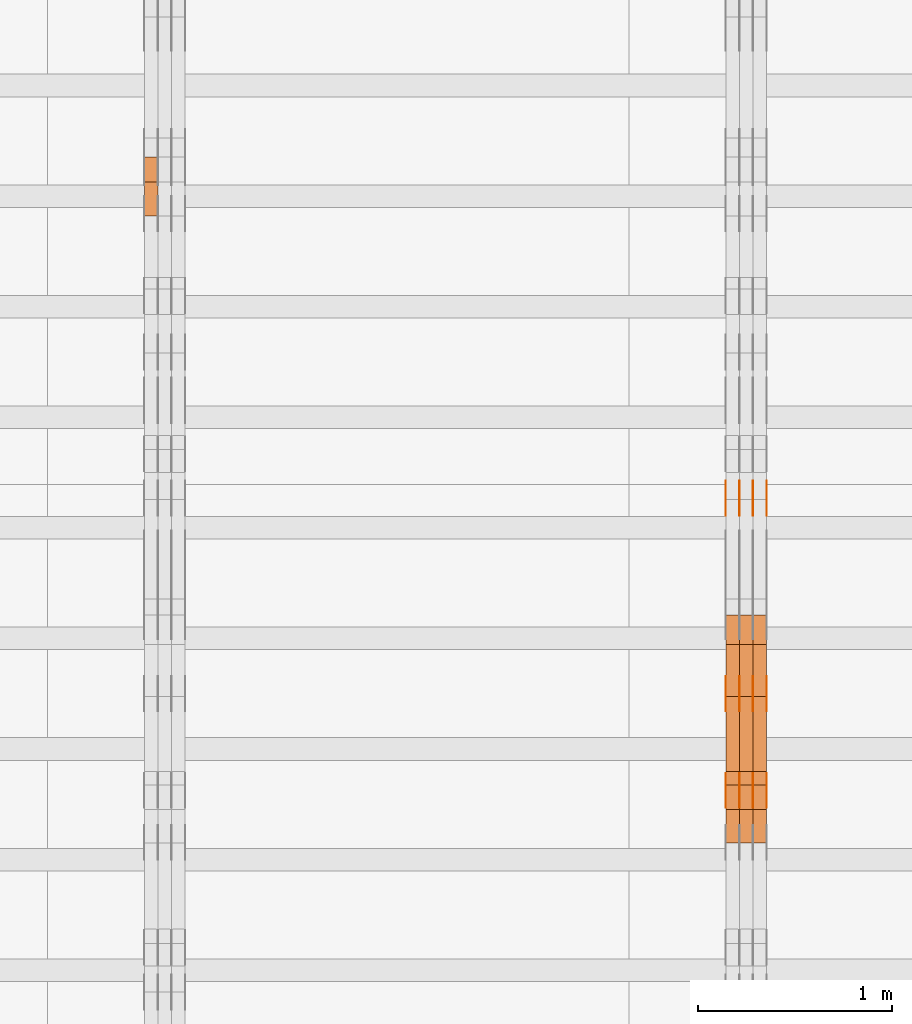
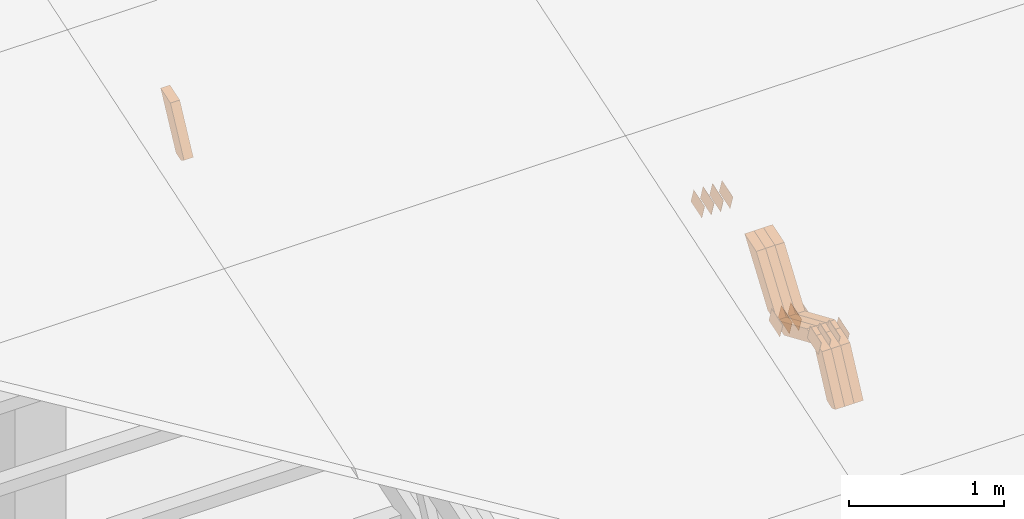
# One storey, part 118 of 385: 28 proxies.
"""IFC2X3 building model written with IfcOpenShell, lengths in millimetres."""

from ifc_helpers import new_model, entity, si_unit, converted_unit, derived_unit, direction, frame, origin, place, context, subcontext, project, spatial, polyline, outline, extrude, source, transform, mapped, material, type_object, type_shapes, element, save


model = new_model("IFC2X3")

# Units and contexts
model_context = context("Model", 3, precision=0.01, world=origin(), true_north=direction((6.12303176911189e-17, 1.0)))
body_context = subcontext(model_context, "Body", "Model", "MODEL_VIEW")
ifc_project = project(units=[si_unit("LENGTHUNIT", "METRE", prefix="MILLI"), si_unit("AREAUNIT", "SQUARE_METRE"), si_unit("VOLUMEUNIT", "CUBIC_METRE"), converted_unit("PLANEANGLEUNIT", "DEGREE", entity("IfcRatioMeasure", 0.0174532925199433), si_unit("PLANEANGLEUNIT", "RADIAN"), dimensions=[0, 0, 0, 0, 0, 0, 0]), si_unit("MASSUNIT", "GRAM", prefix="KILO"), derived_unit("MASSDENSITYUNIT", [(si_unit("MASSUNIT", "GRAM", prefix="KILO"), 1), (si_unit("LENGTHUNIT", "METRE"), -3)]), si_unit("TIMEUNIT", "SECOND"), si_unit("FREQUENCYUNIT", "HERTZ"), si_unit("THERMODYNAMICTEMPERATUREUNIT", "DEGREE_CELSIUS"), derived_unit("THERMALTRANSMITTANCEUNIT", [(si_unit("MASSUNIT", "GRAM", prefix="KILO"), 1), (si_unit("THERMODYNAMICTEMPERATUREUNIT", "KELVIN"), -1), (si_unit("TIMEUNIT", "SECOND"), -3)]), derived_unit("VOLUMETRICFLOWRATEUNIT", [(si_unit("LENGTHUNIT", "METRE"), 3), (si_unit("TIMEUNIT", "SECOND"), -1)]), si_unit("ELECTRICCURRENTUNIT", "AMPERE"), si_unit("ELECTRICVOLTAGEUNIT", "VOLT"), si_unit("POWERUNIT", "WATT"), si_unit("FORCEUNIT", "NEWTON", prefix="KILO"), si_unit("ILLUMINANCEUNIT", "LUX"), si_unit("LUMINOUSFLUXUNIT", "LUMEN"), si_unit("LUMINOUSINTENSITYUNIT", "CANDELA"), derived_unit("USERDEFINED", [(si_unit("MASSUNIT", "GRAM", prefix="KILO"), -1), (si_unit("LENGTHUNIT", "METRE"), -2), (si_unit("TIMEUNIT", "SECOND"), 3), (si_unit("LUMINOUSFLUXUNIT", "LUMEN"), 1)]), derived_unit("LINEARVELOCITYUNIT", [(si_unit("LENGTHUNIT", "METRE"), 1), (si_unit("TIMEUNIT", "SECOND"), -1)]), si_unit("PRESSUREUNIT", "PASCAL"), derived_unit("USERDEFINED", [(si_unit("LENGTHUNIT", "METRE"), -2), (si_unit("MASSUNIT", "GRAM", prefix="KILO"), 1), (si_unit("TIMEUNIT", "SECOND"), -2)])], contexts=[model_context])

# Site, building, storey
site_placement = place(None, origin())
site = spatial("IfcSite", under=ifc_project, at=site_placement, CompositionType="ELEMENT")
building_placement = place(site_placement, origin())
building = spatial("IfcBuilding", under=site, at=building_placement, CompositionType="ELEMENT")
storey_placement = place(building_placement, origin())
storey = spatial("IfcBuildingStorey", under=building, at=storey_placement, Name="Default", CompositionType="ELEMENT", Elevation=0.0)

# Proxies
ifc_material_1 = material(Name="IfcSurfaceStyle #281766")
building_element_proxy_type_1 = type_object("IfcBuildingElementProxyType", PredefinedType="NOTDEFINED", material=ifc_material_1)
shared_shape_1 = source(origin(), body_context, "Body", "SweptSolid", [
    extrude(outline(polyline([(-74.9998565677179, -60.000059685226), (74.9998794200128, -60.000059685226), (74.9998565677179, 60.000059685226), (-74.9998794200128, 60.000059685226), (-74.9998565677179, -60.000059685226)])), frame((75.0001976720505, 60.000059685226, 0.0), z_axis=(0.0, 0.0, 1.0), x_axis=(-1.0, 0.0, 0.0)), (0.0, 0.0, 1.0), 1.3),
])
type_shapes(building_element_proxy_type_1, [shared_shape_1])
proxy_1_placement = place(building_placement, frame((21386.3, 8537.53090236182, 1950.11166041942), z_axis=(-1.0, 0.0, 0.0), x_axis=(0.0, 0.951056516295124, 0.309016994375039)))
element("IfcBuildingElementProxy", 1, at=proxy_1_placement, inside=storey, type_object=building_element_proxy_type_1, material=ifc_material_1, context=body_context, shape_type="MappedRepresentation", body=[
    mapped(shared_shape_1, transform((0.0, 0.0, 0.0), scale=1.0)),
])
ifc_material_2 = material(Name="IfcSurfaceStyle #281709")
building_element_proxy_type_2 = type_object("IfcBuildingElementProxyType", PredefinedType="NOTDEFINED", material=ifc_material_2)
shared_shape_2 = source(origin(), body_context, "Body", "SweptSolid", [
    extrude(outline(polyline([(-74.9998565677179, -60.000059685226), (74.9998794200128, -60.000059685226), (74.9998565677179, 60.000059685226), (-74.9998794200128, 60.000059685226), (-74.9998565677179, -60.000059685226)])), frame((75.0001976720505, 60.000059685226, 0.0), z_axis=(0.0, 0.0, 1.0), x_axis=(-1.0, 0.0, 0.0)), (0.0, 0.0, 1.0), 1.3),
])
type_shapes(building_element_proxy_type_2, [shared_shape_2])
proxy_2_placement = place(building_placement, frame((21315.0, 8537.53090236182, 1950.11166041942), z_axis=(-1.0, 0.0, 0.0), x_axis=(0.0, 0.951056516295124, 0.309016994375039)))
element("IfcBuildingElementProxy", 2, at=proxy_2_placement, inside=storey, type_object=building_element_proxy_type_2, material=ifc_material_2, context=body_context, shape_type="MappedRepresentation", body=[
    mapped(shared_shape_2, transform((0.0, 0.0, 0.0), scale=1.0)),
])
ifc_material_3 = material(Name="IfcSurfaceStyle #281652")
building_element_proxy_type_3 = type_object("IfcBuildingElementProxyType", PredefinedType="NOTDEFINED", material=ifc_material_3)
shared_shape_3 = source(origin(), body_context, "Body", "SweptSolid", [
    extrude(outline(polyline([(-74.9998565677179, -60.000059685226), (74.9998794200128, -60.000059685226), (74.9998565677179, 60.000059685226), (-74.9998794200128, 60.000059685226), (-74.9998565677179, -60.000059685226)])), frame((75.0001976720505, 60.000059685226, 0.0), z_axis=(0.0, 0.0, 1.0), x_axis=(-1.0, 0.0, 0.0)), (0.0, 0.0, 1.0), 1.3),
])
type_shapes(building_element_proxy_type_3, [shared_shape_3])
proxy_3_placement = place(building_placement, frame((21316.3, 8537.53090236182, 1950.11166041942), z_axis=(-1.0, 0.0, 0.0), x_axis=(0.0, 0.951056516295124, 0.309016994375039)))
element("IfcBuildingElementProxy", 3, at=proxy_3_placement, inside=storey, type_object=building_element_proxy_type_3, material=ifc_material_3, context=body_context, shape_type="MappedRepresentation", body=[
    mapped(shared_shape_3, transform((0.0, 0.0, 0.0), scale=1.0)),
])
ifc_material_4 = material(Name="IfcSurfaceStyle #281595")
building_element_proxy_type_4 = type_object("IfcBuildingElementProxyType", PredefinedType="NOTDEFINED", material=ifc_material_4)
shared_shape_4 = source(origin(), body_context, "Body", "SweptSolid", [
    extrude(outline(polyline([(-74.9998565677179, -60.000059685226), (74.9998794200128, -60.000059685226), (74.9998565677179, 60.000059685226), (-74.9998794200128, 60.000059685226), (-74.9998565677179, -60.000059685226)])), frame((75.0001976720505, 60.000059685226, 0.0), z_axis=(0.0, 0.0, 1.0), x_axis=(-1.0, 0.0, 0.0)), (0.0, 0.0, 1.0), 1.29999999999999),
])
type_shapes(building_element_proxy_type_4, [shared_shape_4])
proxy_4_placement = place(building_placement, frame((21245.0, 8537.53090236182, 1950.11166041942), z_axis=(-1.0, 0.0, 0.0), x_axis=(0.0, 0.951056516295124, 0.309016994375039)))
element("IfcBuildingElementProxy", 4, at=proxy_4_placement, inside=storey, type_object=building_element_proxy_type_4, material=ifc_material_4, context=body_context, shape_type="MappedRepresentation", body=[
    mapped(shared_shape_4, transform((0.0, 0.0, 0.0), scale=1.0)),
])
ifc_material_5 = material(Name="IfcSurfaceStyle #281538")
building_element_proxy_type_5 = type_object("IfcBuildingElementProxyType", PredefinedType="NOTDEFINED", material=ifc_material_5)
shared_shape_5 = source(origin(), body_context, "Body", "SweptSolid", [
    extrude(outline(polyline([(-74.9998565677179, -60.000059685226), (74.9998794200128, -60.000059685226), (74.9998565677179, 60.000059685226), (-74.9998794200128, 60.000059685226), (-74.9998565677179, -60.000059685226)])), frame((75.0001976720505, 60.000059685226, 0.0), z_axis=(0.0, 0.0, 1.0), x_axis=(-1.0, 0.0, 0.0)), (0.0, 0.0, 1.0), 1.29999999999999),
])
type_shapes(building_element_proxy_type_5, [shared_shape_5])
proxy_5_placement = place(building_placement, frame((21246.3, 8537.53090236182, 1950.11166041942), z_axis=(-1.0, 0.0, 0.0), x_axis=(0.0, 0.951056516295124, 0.309016994375039)))
element("IfcBuildingElementProxy", 5, at=proxy_5_placement, inside=storey, type_object=building_element_proxy_type_5, material=ifc_material_5, context=body_context, shape_type="MappedRepresentation", body=[
    mapped(shared_shape_5, transform((0.0, 0.0, 0.0), scale=1.0)),
])
ifc_material_6 = material(Name="IfcSurfaceStyle #281481")
building_element_proxy_type_6 = type_object("IfcBuildingElementProxyType", PredefinedType="NOTDEFINED", material=ifc_material_6)
shared_shape_6 = source(origin(), body_context, "Body", "SweptSolid", [
    extrude(outline(polyline([(-74.9998565677179, -60.000059685226), (74.9998794200128, -60.000059685226), (74.9998565677179, 60.000059685226), (-74.9998794200128, 60.000059685226), (-74.9998565677179, -60.000059685226)])), frame((75.0001976720505, 60.000059685226, 0.0), z_axis=(0.0, 0.0, 1.0), x_axis=(-1.0, 0.0, 0.0)), (0.0, 0.0, 1.0), 1.29999999999999),
])
type_shapes(building_element_proxy_type_6, [shared_shape_6])
proxy_6_placement = place(building_placement, frame((21175.0, 8537.53090236182, 1950.11166041942), z_axis=(-1.0, 0.0, 0.0), x_axis=(0.0, 0.951056516295124, 0.309016994375039)))
element("IfcBuildingElementProxy", 6, at=proxy_6_placement, inside=storey, type_object=building_element_proxy_type_6, material=ifc_material_6, context=body_context, shape_type="MappedRepresentation", body=[
    mapped(shared_shape_6, transform((0.0, 0.0, 0.0), scale=1.0)),
])
ifc_material_7 = material(Name="IfcSurfaceStyle #276636")
building_element_proxy_type_7 = type_object("IfcBuildingElementProxyType", PredefinedType="NOTDEFINED", material=ifc_material_7)
shared_shape_7 = source(origin(), body_context, "Body", "SweptSolid", [
    extrude(outline(polyline([(-74.9998565677169, -60.0000596852269), (74.9998794200137, -60.0000596852269), (74.9998565677151, 60.0000596852269), (-74.9998794200119, 60.0000596852269), (-74.9998565677169, -60.0000596852269)])), frame((74.9998794200137, 60.0000596852269, 0.0), z_axis=(0.0, 0.0, 1.0), x_axis=(-1.0, 0.0, 0.0)), (0.0, 0.0, 1.0), 1.3),
])
type_shapes(building_element_proxy_type_7, [shared_shape_7])
proxy_7_placement = place(building_placement, frame((21386.3, 7527.6269081625, 1621.97418552253), z_axis=(-1.0, 0.0, 0.0), x_axis=(0.0, 0.951056516295124, 0.309016994375039)))
element("IfcBuildingElementProxy", 7, at=proxy_7_placement, inside=storey, type_object=building_element_proxy_type_7, material=ifc_material_7, context=body_context, shape_type="MappedRepresentation", body=[
    mapped(shared_shape_7, transform((0.0, 0.0, 0.0), scale=1.0)),
])
ifc_material_8 = material(Name="IfcSurfaceStyle #276579")
building_element_proxy_type_8 = type_object("IfcBuildingElementProxyType", PredefinedType="NOTDEFINED", material=ifc_material_8)
shared_shape_8 = source(origin(), body_context, "Body", "SweptSolid", [
    extrude(outline(polyline([(-74.9998565677169, -60.0000596852269), (74.9998794200137, -60.0000596852269), (74.9998565677151, 60.0000596852269), (-74.9998794200119, 60.0000596852269), (-74.9998565677169, -60.0000596852269)])), frame((74.9998794200137, 60.0000596852269, 0.0), z_axis=(0.0, 0.0, 1.0), x_axis=(-1.0, 0.0, 0.0)), (0.0, 0.0, 1.0), 1.3),
])
type_shapes(building_element_proxy_type_8, [shared_shape_8])
proxy_8_placement = place(building_placement, frame((21315.0, 7527.6269081625, 1621.97418552253), z_axis=(-1.0, 0.0, 0.0), x_axis=(0.0, 0.951056516295124, 0.309016994375039)))
element("IfcBuildingElementProxy", 8, at=proxy_8_placement, inside=storey, type_object=building_element_proxy_type_8, material=ifc_material_8, context=body_context, shape_type="MappedRepresentation", body=[
    mapped(shared_shape_8, transform((0.0, 0.0, 0.0), scale=1.0)),
])
ifc_material_9 = material(Name="IfcSurfaceStyle #276522")
building_element_proxy_type_9 = type_object("IfcBuildingElementProxyType", PredefinedType="NOTDEFINED", material=ifc_material_9)
shared_shape_9 = source(origin(), body_context, "Body", "SweptSolid", [
    extrude(outline(polyline([(-74.9998565677169, -60.0000596852269), (74.9998794200137, -60.0000596852269), (74.9998565677151, 60.0000596852269), (-74.9998794200119, 60.0000596852269), (-74.9998565677169, -60.0000596852269)])), frame((74.9998794200137, 60.0000596852269, 0.0), z_axis=(0.0, 0.0, 1.0), x_axis=(-1.0, 0.0, 0.0)), (0.0, 0.0, 1.0), 1.3),
])
type_shapes(building_element_proxy_type_9, [shared_shape_9])
proxy_9_placement = place(building_placement, frame((21316.3, 7527.6269081625, 1621.97418552253), z_axis=(-1.0, 0.0, 0.0), x_axis=(0.0, 0.951056516295124, 0.309016994375039)))
element("IfcBuildingElementProxy", 9, at=proxy_9_placement, inside=storey, type_object=building_element_proxy_type_9, material=ifc_material_9, context=body_context, shape_type="MappedRepresentation", body=[
    mapped(shared_shape_9, transform((0.0, 0.0, 0.0), scale=1.0)),
])
ifc_material_10 = material(Name="IfcSurfaceStyle #276465")
building_element_proxy_type_10 = type_object("IfcBuildingElementProxyType", PredefinedType="NOTDEFINED", material=ifc_material_10)
shared_shape_10 = source(origin(), body_context, "Body", "SweptSolid", [
    extrude(outline(polyline([(-74.9998565677169, -60.0000596852269), (74.9998794200137, -60.0000596852269), (74.9998565677151, 60.0000596852269), (-74.9998794200119, 60.0000596852269), (-74.9998565677169, -60.0000596852269)])), frame((74.9998794200137, 60.0000596852269, 0.0), z_axis=(0.0, 0.0, 1.0), x_axis=(-1.0, 0.0, 0.0)), (0.0, 0.0, 1.0), 1.29999999999999),
])
type_shapes(building_element_proxy_type_10, [shared_shape_10])
proxy_10_placement = place(building_placement, frame((21245.0, 7527.6269081625, 1621.97418552253), z_axis=(-1.0, 0.0, 0.0), x_axis=(0.0, 0.951056516295124, 0.309016994375039)))
element("IfcBuildingElementProxy", 10, at=proxy_10_placement, inside=storey, type_object=building_element_proxy_type_10, material=ifc_material_10, context=body_context, shape_type="MappedRepresentation", body=[
    mapped(shared_shape_10, transform((0.0, 0.0, 0.0), scale=1.0)),
])
ifc_material_11 = material(Name="IfcSurfaceStyle #276408")
building_element_proxy_type_11 = type_object("IfcBuildingElementProxyType", PredefinedType="NOTDEFINED", material=ifc_material_11)
shared_shape_11 = source(origin(), body_context, "Body", "SweptSolid", [
    extrude(outline(polyline([(-74.9998565677169, -60.0000596852269), (74.9998794200137, -60.0000596852269), (74.9998565677151, 60.0000596852269), (-74.9998794200119, 60.0000596852269), (-74.9998565677169, -60.0000596852269)])), frame((74.9998794200137, 60.0000596852269, 0.0), z_axis=(0.0, 0.0, 1.0), x_axis=(-1.0, 0.0, 0.0)), (0.0, 0.0, 1.0), 1.29999999999999),
])
type_shapes(building_element_proxy_type_11, [shared_shape_11])
proxy_11_placement = place(building_placement, frame((21246.3, 7527.6269081625, 1621.97418552253), z_axis=(-1.0, 0.0, 0.0), x_axis=(0.0, 0.951056516295124, 0.309016994375039)))
element("IfcBuildingElementProxy", 11, at=proxy_11_placement, inside=storey, type_object=building_element_proxy_type_11, material=ifc_material_11, context=body_context, shape_type="MappedRepresentation", body=[
    mapped(shared_shape_11, transform((0.0, 0.0, 0.0), scale=1.0)),
])
ifc_material_12 = material(Name="IfcSurfaceStyle #276351")
building_element_proxy_type_12 = type_object("IfcBuildingElementProxyType", PredefinedType="NOTDEFINED", material=ifc_material_12)
shared_shape_12 = source(origin(), body_context, "Body", "SweptSolid", [
    extrude(outline(polyline([(-74.9998565677169, -60.0000596852269), (74.9998794200137, -60.0000596852269), (74.9998565677151, 60.0000596852269), (-74.9998794200119, 60.0000596852269), (-74.9998565677169, -60.0000596852269)])), frame((74.9998794200137, 60.0000596852269, 0.0), z_axis=(0.0, 0.0, 1.0), x_axis=(-1.0, 0.0, 0.0)), (0.0, 0.0, 1.0), 1.29999999999999),
])
type_shapes(building_element_proxy_type_12, [shared_shape_12])
proxy_12_placement = place(building_placement, frame((21175.0, 7527.6269081625, 1621.97418552253), z_axis=(-1.0, 0.0, 0.0), x_axis=(0.0, 0.951056516295124, 0.309016994375039)))
element("IfcBuildingElementProxy", 12, at=proxy_12_placement, inside=storey, type_object=building_element_proxy_type_12, material=ifc_material_12, context=body_context, shape_type="MappedRepresentation", body=[
    mapped(shared_shape_12, transform((0.0, 0.0, 0.0), scale=1.0)),
])
ifc_material_13 = material(Name="IfcSurfaceStyle #266376")
building_element_proxy_type_13 = type_object("IfcBuildingElementProxyType", PredefinedType="NOTDEFINED", material=ifc_material_13)
shared_shape_13 = source(origin(), body_context, "Body", "SweptSolid", [
    extrude(outline(polyline([(-74.9998565677233, -60.0000596852342), (74.9998794200074, -60.0000596852342), (74.9998565677233, 60.0000596852342), (-74.9998794200074, 60.0000596852342), (-74.9998565677233, -60.0000596852342)])), frame((74.9998794200073, 60.0000596852342, 0.0), z_axis=(0.0, 0.0, 1.0), x_axis=(-1.0, 0.0, 0.0)), (0.0, 0.0, 1.0), 1.3),
])
type_shapes(building_element_proxy_type_13, [shared_shape_13])
proxy_13_placement = place(building_placement, frame((21386.3, 7029.15620503751, 1786.70025974129), z_axis=(-1.0, 0.0, 0.0), x_axis=(0.0, 0.951056516295154, 0.309016994374948)))
element("IfcBuildingElementProxy", 13, at=proxy_13_placement, inside=storey, type_object=building_element_proxy_type_13, material=ifc_material_13, context=body_context, shape_type="MappedRepresentation", body=[
    mapped(shared_shape_13, transform((0.0, 0.0, 0.0), scale=1.0)),
])
ifc_material_14 = material(Name="IfcSurfaceStyle #266319")
building_element_proxy_type_14 = type_object("IfcBuildingElementProxyType", PredefinedType="NOTDEFINED", material=ifc_material_14)
shared_shape_14 = source(origin(), body_context, "Body", "SweptSolid", [
    extrude(outline(polyline([(-74.9998565677233, -60.0000596852342), (74.9998794200074, -60.0000596852342), (74.9998565677233, 60.0000596852342), (-74.9998794200074, 60.0000596852342), (-74.9998565677233, -60.0000596852342)])), frame((74.9998794200073, 60.0000596852342, 0.0), z_axis=(0.0, 0.0, 1.0), x_axis=(-1.0, 0.0, 0.0)), (0.0, 0.0, 1.0), 1.3),
])
type_shapes(building_element_proxy_type_14, [shared_shape_14])
proxy_14_placement = place(building_placement, frame((21315.0, 7029.15620503751, 1786.70025974129), z_axis=(-1.0, 0.0, 0.0), x_axis=(0.0, 0.951056516295154, 0.309016994374948)))
element("IfcBuildingElementProxy", 14, at=proxy_14_placement, inside=storey, type_object=building_element_proxy_type_14, material=ifc_material_14, context=body_context, shape_type="MappedRepresentation", body=[
    mapped(shared_shape_14, transform((0.0, 0.0, 0.0), scale=1.0)),
])
ifc_material_15 = material(Name="IfcSurfaceStyle #266262")
building_element_proxy_type_15 = type_object("IfcBuildingElementProxyType", PredefinedType="NOTDEFINED", material=ifc_material_15)
shared_shape_15 = source(origin(), body_context, "Body", "SweptSolid", [
    extrude(outline(polyline([(-74.9998565677233, -60.0000596852342), (74.9998794200074, -60.0000596852342), (74.9998565677233, 60.0000596852342), (-74.9998794200074, 60.0000596852342), (-74.9998565677233, -60.0000596852342)])), frame((74.9998794200073, 60.0000596852342, 0.0), z_axis=(0.0, 0.0, 1.0), x_axis=(-1.0, 0.0, 0.0)), (0.0, 0.0, 1.0), 1.3),
])
type_shapes(building_element_proxy_type_15, [shared_shape_15])
proxy_15_placement = place(building_placement, frame((21316.3, 7029.15620503751, 1786.70025974129), z_axis=(-1.0, 0.0, 0.0), x_axis=(0.0, 0.951056516295154, 0.309016994374948)))
element("IfcBuildingElementProxy", 15, at=proxy_15_placement, inside=storey, type_object=building_element_proxy_type_15, material=ifc_material_15, context=body_context, shape_type="MappedRepresentation", body=[
    mapped(shared_shape_15, transform((0.0, 0.0, 0.0), scale=1.0)),
])
ifc_material_16 = material(Name="IfcSurfaceStyle #266205")
building_element_proxy_type_16 = type_object("IfcBuildingElementProxyType", PredefinedType="NOTDEFINED", material=ifc_material_16)
shared_shape_16 = source(origin(), body_context, "Body", "SweptSolid", [
    extrude(outline(polyline([(-74.9998565677233, -60.0000596852342), (74.9998794200074, -60.0000596852342), (74.9998565677233, 60.0000596852342), (-74.9998794200074, 60.0000596852342), (-74.9998565677233, -60.0000596852342)])), frame((74.9998794200073, 60.0000596852342, 0.0), z_axis=(0.0, 0.0, 1.0), x_axis=(-1.0, 0.0, 0.0)), (0.0, 0.0, 1.0), 1.29999999999999),
])
type_shapes(building_element_proxy_type_16, [shared_shape_16])
proxy_16_placement = place(building_placement, frame((21245.0, 7029.15620503751, 1786.70025974129), z_axis=(-1.0, 0.0, 0.0), x_axis=(0.0, 0.951056516295154, 0.309016994374948)))
element("IfcBuildingElementProxy", 16, at=proxy_16_placement, inside=storey, type_object=building_element_proxy_type_16, material=ifc_material_16, context=body_context, shape_type="MappedRepresentation", body=[
    mapped(shared_shape_16, transform((0.0, 0.0, 0.0), scale=1.0)),
])
ifc_material_17 = material(Name="IfcSurfaceStyle #266148")
building_element_proxy_type_17 = type_object("IfcBuildingElementProxyType", PredefinedType="NOTDEFINED", material=ifc_material_17)
shared_shape_17 = source(origin(), body_context, "Body", "SweptSolid", [
    extrude(outline(polyline([(-74.9998565677233, -60.0000596852342), (74.9998794200074, -60.0000596852342), (74.9998565677233, 60.0000596852342), (-74.9998794200074, 60.0000596852342), (-74.9998565677233, -60.0000596852342)])), frame((74.9998794200073, 60.0000596852342, 0.0), z_axis=(0.0, 0.0, 1.0), x_axis=(-1.0, 0.0, 0.0)), (0.0, 0.0, 1.0), 1.29999999999999),
])
type_shapes(building_element_proxy_type_17, [shared_shape_17])
proxy_17_placement = place(building_placement, frame((21246.3, 7029.15620503751, 1786.70025974129), z_axis=(-1.0, 0.0, 0.0), x_axis=(0.0, 0.951056516295154, 0.309016994374948)))
element("IfcBuildingElementProxy", 17, at=proxy_17_placement, inside=storey, type_object=building_element_proxy_type_17, material=ifc_material_17, context=body_context, shape_type="MappedRepresentation", body=[
    mapped(shared_shape_17, transform((0.0, 0.0, 0.0), scale=1.0)),
])
ifc_material_18 = material(Name="IfcSurfaceStyle #266091")
building_element_proxy_type_18 = type_object("IfcBuildingElementProxyType", PredefinedType="NOTDEFINED", material=ifc_material_18)
shared_shape_18 = source(origin(), body_context, "Body", "SweptSolid", [
    extrude(outline(polyline([(-74.9998565677233, -60.0000596852342), (74.9998794200074, -60.0000596852342), (74.9998565677233, 60.0000596852342), (-74.9998794200074, 60.0000596852342), (-74.9998565677233, -60.0000596852342)])), frame((74.9998794200073, 60.0000596852342, 0.0), z_axis=(0.0, 0.0, 1.0), x_axis=(-1.0, 0.0, 0.0)), (0.0, 0.0, 1.0), 1.29999999999999),
])
type_shapes(building_element_proxy_type_18, [shared_shape_18])
proxy_18_placement = place(building_placement, frame((21175.0, 7029.15620503751, 1786.70025974129), z_axis=(-1.0, 0.0, 0.0), x_axis=(0.0, 0.951056516295154, 0.309016994374948)))
element("IfcBuildingElementProxy", 18, at=proxy_18_placement, inside=storey, type_object=building_element_proxy_type_18, material=ifc_material_18, context=body_context, shape_type="MappedRepresentation", body=[
    mapped(shared_shape_18, transform((0.0, 0.0, 0.0), scale=1.0)),
])
ifc_material_19 = material(Name="IfcSurfaceStyle #253884")
building_element_proxy_type_19 = type_object("IfcBuildingElementProxyType", Name="T1-W17 253882", PredefinedType="NOTDEFINED", material=ifc_material_19)
shared_shape_19 = source(origin(), body_context, "Body", "SweptSolid", [
    extrude(outline(polyline([(-364.271754334175, -47.5002955168173), (154.762247185537, -47.5002955168173), (218.32500198375, 4.1746158945366e-05), (228.330650189718, 47.5002746437378), (-237.14614502483, 47.5002746437378), (-364.271754334175, -47.5002955168173)])), frame((228.330650189718, 47.5002746437378, 0.0), z_axis=(0.0, 0.0, 1.0), x_axis=(-1.0, 0.0, 0.0)), (0.0, 0.0, 1.0), 70.0),
])
type_shapes(building_element_proxy_type_19, [shared_shape_19])
proxy_19_placement = place(building_placement, frame((21385.0, 7603.591796875, 1617.27880859375), z_axis=(-1.0, 0.0, 0.0), x_axis=(0.0, 0.576852646364743, 0.816848226038346)))
element("IfcBuildingElementProxy", 19, at=proxy_19_placement, inside=storey, type_object=building_element_proxy_type_19, material=ifc_material_19, Name="T1-W17", context=body_context, shape_type="MappedRepresentation", body=[
    mapped(shared_shape_19, transform((0.0, 0.0, 0.0), scale=1.0)),
])
ifc_material_20 = material(Name="IfcSurfaceStyle #253818")
building_element_proxy_type_20 = type_object("IfcBuildingElementProxyType", Name="T1-W17 253816", PredefinedType="NOTDEFINED", material=ifc_material_20)
shared_shape_20 = source(origin(), body_context, "Body", "SweptSolid", [
    extrude(outline(polyline([(-364.271754334175, -47.5002955168173), (154.762247185537, -47.5002955168173), (218.32500198375, 4.1746158945366e-05), (228.330650189718, 47.5002746437378), (-237.14614502483, 47.5002746437378), (-364.271754334175, -47.5002955168173)])), frame((228.330650189718, 47.5002746437378, 0.0), z_axis=(0.0, 0.0, 1.0), x_axis=(-1.0, 0.0, 0.0)), (0.0, 0.0, 1.0), 70.0),
])
type_shapes(building_element_proxy_type_20, [shared_shape_20])
proxy_20_placement = place(building_placement, frame((21315.0, 7603.591796875, 1617.27880859375), z_axis=(-1.0, 0.0, 0.0), x_axis=(0.0, 0.576852646364743, 0.816848226038346)))
element("IfcBuildingElementProxy", 20, at=proxy_20_placement, inside=storey, type_object=building_element_proxy_type_20, material=ifc_material_20, Name="T1-W17", context=body_context, shape_type="MappedRepresentation", body=[
    mapped(shared_shape_20, transform((0.0, 0.0, 0.0), scale=1.0)),
])
ifc_material_21 = material(Name="IfcSurfaceStyle #253752")
building_element_proxy_type_21 = type_object("IfcBuildingElementProxyType", Name="T1-W17 253750", PredefinedType="NOTDEFINED", material=ifc_material_21)
shared_shape_21 = source(origin(), body_context, "Body", "SweptSolid", [
    extrude(outline(polyline([(-364.271754334175, -47.5002955168173), (154.762247185537, -47.5002955168173), (218.32500198375, 4.1746158945366e-05), (228.330650189718, 47.5002746437378), (-237.14614502483, 47.5002746437378), (-364.271754334175, -47.5002955168173)])), frame((228.330650189718, 47.5002746437378, 0.0), z_axis=(0.0, 0.0, 1.0), x_axis=(-1.0, 0.0, 0.0)), (0.0, 0.0, 1.0), 70.0),
])
type_shapes(building_element_proxy_type_21, [shared_shape_21])
proxy_21_placement = place(building_placement, frame((21245.0, 7603.591796875, 1617.27880859375), z_axis=(-1.0, 0.0, 0.0), x_axis=(0.0, 0.576852646364743, 0.816848226038346)))
element("IfcBuildingElementProxy", 21, at=proxy_21_placement, inside=storey, type_object=building_element_proxy_type_21, material=ifc_material_21, Name="T1-W17", context=body_context, shape_type="MappedRepresentation", body=[
    mapped(shared_shape_21, transform((0.0, 0.0, 0.0), scale=1.0)),
])
ifc_material_22 = material(Name="IfcSurfaceStyle #253488")
building_element_proxy_type_22 = type_object("IfcBuildingElementProxyType", Name="T1-W28 253486", PredefinedType="NOTDEFINED", material=ifc_material_22)
shared_shape_22 = source(origin(), body_context, "Body", "SweptSolid", [
    extrude(outline(polyline([(-217.926999432742, -47.5002417204892), (200.85556309928, -47.5002417204892), (198.503183549447, 8.27993157516647e-05), (144.500539771884, 47.5002003208314), (-325.932286987868, 47.5002003208314), (-217.926999432742, -47.5002417204892)])), frame((200.855855188284, 47.5002003208314, 0.0), z_axis=(0.0, 0.0, 1.0), x_axis=(-1.0, 0.0, 0.0)), (0.0, 0.0, 1.0), 70.0),
])
type_shapes(building_element_proxy_type_22, [shared_shape_22])
proxy_22_placement = place(building_placement, frame((21385.0, 7164.46308589723, 1806.71154838415), z_axis=(-1.0, 0.0, 0.0), x_axis=(0.0, 0.918207947119617, -0.396098681954861)))
element("IfcBuildingElementProxy", 22, at=proxy_22_placement, inside=storey, type_object=building_element_proxy_type_22, material=ifc_material_22, Name="T1-W28", context=body_context, shape_type="MappedRepresentation", body=[
    mapped(shared_shape_22, transform((0.0, 0.0, 0.0), scale=1.0)),
])
ifc_material_23 = material(Name="IfcSurfaceStyle #253422")
building_element_proxy_type_23 = type_object("IfcBuildingElementProxyType", Name="T1-W28 253420", PredefinedType="NOTDEFINED", material=ifc_material_23)
shared_shape_23 = source(origin(), body_context, "Body", "SweptSolid", [
    extrude(outline(polyline([(-217.926999432742, -47.5002417204892), (200.85556309928, -47.5002417204892), (198.503183549447, 8.27993157516647e-05), (144.500539771884, 47.5002003208314), (-325.932286987868, 47.5002003208314), (-217.926999432742, -47.5002417204892)])), frame((200.855855188284, 47.5002003208314, 0.0), z_axis=(0.0, 0.0, 1.0), x_axis=(-1.0, 0.0, 0.0)), (0.0, 0.0, 1.0), 70.0),
])
type_shapes(building_element_proxy_type_23, [shared_shape_23])
proxy_23_placement = place(building_placement, frame((21315.0, 7164.46308589723, 1806.71154838415), z_axis=(-1.0, 0.0, 0.0), x_axis=(0.0, 0.918207947119617, -0.396098681954861)))
element("IfcBuildingElementProxy", 23, at=proxy_23_placement, inside=storey, type_object=building_element_proxy_type_23, material=ifc_material_23, Name="T1-W28", context=body_context, shape_type="MappedRepresentation", body=[
    mapped(shared_shape_23, transform((0.0, 0.0, 0.0), scale=1.0)),
])
ifc_material_24 = material(Name="IfcSurfaceStyle #253356")
building_element_proxy_type_24 = type_object("IfcBuildingElementProxyType", Name="T1-W28 253354", PredefinedType="NOTDEFINED", material=ifc_material_24)
shared_shape_24 = source(origin(), body_context, "Body", "SweptSolid", [
    extrude(outline(polyline([(-217.926999432742, -47.5002417204892), (200.85556309928, -47.5002417204892), (198.503183549447, 8.27993157516647e-05), (144.500539771884, 47.5002003208314), (-325.932286987868, 47.5002003208314), (-217.926999432742, -47.5002417204892)])), frame((200.855855188284, 47.5002003208314, 0.0), z_axis=(0.0, 0.0, 1.0), x_axis=(-1.0, 0.0, 0.0)), (0.0, 0.0, 1.0), 70.0),
])
type_shapes(building_element_proxy_type_24, [shared_shape_24])
proxy_24_placement = place(building_placement, frame((21245.0, 7164.46308589723, 1806.71154838415), z_axis=(-1.0, 0.0, 0.0), x_axis=(0.0, 0.918207947119617, -0.396098681954861)))
element("IfcBuildingElementProxy", 24, at=proxy_24_placement, inside=storey, type_object=building_element_proxy_type_24, material=ifc_material_24, Name="T1-W28", context=body_context, shape_type="MappedRepresentation", body=[
    mapped(shared_shape_24, transform((0.0, 0.0, 0.0), scale=1.0)),
])
ifc_material_25 = material(Name="IfcSurfaceStyle #253092")
building_element_proxy_type_25 = type_object("IfcBuildingElementProxyType", Name="T1-W38 253090", PredefinedType="NOTDEFINED", material=ifc_material_25)
shared_shape_25 = source(origin(), body_context, "Body", "SweptSolid", [
    extrude(outline(polyline([(-298.027186733919, -47.5000251939178), (135.138415004037, -47.5000251939178), (181.282052802132, 0.000918984287993996), (187.347601017465, 47.4995657017738), (-205.740882089715, 47.4995657017739), (-298.027186733919, -47.5000251939178)])), frame((187.347846776827, 47.5001085012031, 0.0), z_axis=(0.0, 0.0, 1.0), x_axis=(-1.0, 0.0, 0.0)), (0.0, 0.0, 1.0), 70.0),
])
type_shapes(building_element_proxy_type_25, [shared_shape_25])
proxy_25_placement = place(building_placement, frame((21385.0, 6848.47987320449, 1368.44362234215), z_axis=(-1.0, 0.0, 0.0), x_axis=(0.0, 0.441034274474743, 0.897490261082836)))
element("IfcBuildingElementProxy", 25, at=proxy_25_placement, inside=storey, type_object=building_element_proxy_type_25, material=ifc_material_25, Name="T1-W38", context=body_context, shape_type="MappedRepresentation", body=[
    mapped(shared_shape_25, transform((0.0, 0.0, 0.0), scale=1.0)),
])
ifc_material_26 = material(Name="IfcSurfaceStyle #253026")
building_element_proxy_type_26 = type_object("IfcBuildingElementProxyType", Name="T1-W38 253024", PredefinedType="NOTDEFINED", material=ifc_material_26)
shared_shape_26 = source(origin(), body_context, "Body", "SweptSolid", [
    extrude(outline(polyline([(-298.027186733919, -47.5000251939178), (135.138415004037, -47.5000251939178), (181.282052802132, 0.000918984287993996), (187.347601017465, 47.4995657017738), (-205.740882089715, 47.4995657017739), (-298.027186733919, -47.5000251939178)])), frame((187.347846776827, 47.5001085012031, 0.0), z_axis=(0.0, 0.0, 1.0), x_axis=(-1.0, 0.0, 0.0)), (0.0, 0.0, 1.0), 70.0),
])
type_shapes(building_element_proxy_type_26, [shared_shape_26])
proxy_26_placement = place(building_placement, frame((21315.0, 6848.47987320449, 1368.44362234215), z_axis=(-1.0, 0.0, 0.0), x_axis=(0.0, 0.441034274474743, 0.897490261082836)))
element("IfcBuildingElementProxy", 26, at=proxy_26_placement, inside=storey, type_object=building_element_proxy_type_26, material=ifc_material_26, Name="T1-W38", context=body_context, shape_type="MappedRepresentation", body=[
    mapped(shared_shape_26, transform((0.0, 0.0, 0.0), scale=1.0)),
])
ifc_material_27 = material(Name="IfcSurfaceStyle #252960")
building_element_proxy_type_27 = type_object("IfcBuildingElementProxyType", Name="T1-W38 252958", PredefinedType="NOTDEFINED", material=ifc_material_27)
shared_shape_27 = source(origin(), body_context, "Body", "SweptSolid", [
    extrude(outline(polyline([(-298.027186733919, -47.5000251939178), (135.138415004037, -47.5000251939178), (181.282052802132, 0.000918984287993996), (187.347601017465, 47.4995657017738), (-205.740882089715, 47.4995657017739), (-298.027186733919, -47.5000251939178)])), frame((187.347846776827, 47.5001085012031, 0.0), z_axis=(0.0, 0.0, 1.0), x_axis=(-1.0, 0.0, 0.0)), (0.0, 0.0, 1.0), 70.0),
])
type_shapes(building_element_proxy_type_27, [shared_shape_27])
proxy_27_placement = place(building_placement, frame((21245.0, 6848.47987320449, 1368.44362234215), z_axis=(-1.0, 0.0, 0.0), x_axis=(0.0, 0.441034274474743, 0.897490261082836)))
element("IfcBuildingElementProxy", 27, at=proxy_27_placement, inside=storey, type_object=building_element_proxy_type_27, material=ifc_material_27, Name="T1-W38", context=body_context, shape_type="MappedRepresentation", body=[
    mapped(shared_shape_27, transform((0.0, 0.0, 0.0), scale=1.0)),
])
ifc_material_28 = material(Name="IfcSurfaceStyle #221696")
building_element_proxy_type_28 = type_object("IfcBuildingElementProxyType", Name="T1-W37 221694", PredefinedType="NOTDEFINED", material=ifc_material_28)
shared_shape_28 = source(origin(), body_context, "Body", "SweptSolid", [
    extrude(outline(polyline([(111.787482004227, -179.289397746839), (245.990585035629, -179.289397746839), (-64.0177573255029, 131.410401861866), (-131.116409377007, 131.410958895698), (-162.643900337347, 95.757434736113), (111.787482004227, -179.289397746839)])), frame((185.635323570343, 47.5011799885346, 0.0), z_axis=(0.0, 0.0, 1.0), x_axis=(0.706316677358935, 0.707896003156279, 0.0)), (0.0, 0.0, 1.0), 70.0),
])
type_shapes(building_element_proxy_type_28, [shared_shape_28])
proxy_28_placement = place(building_placement, frame((18245.0, 10081.8581176196, 2424.08390440728), z_axis=(-1.0, 0.0, 0.0), x_axis=(0.0, 0.452995827831714, 0.891512635898707)))
element("IfcBuildingElementProxy", 28, at=proxy_28_placement, inside=storey, type_object=building_element_proxy_type_28, material=ifc_material_28, Name="T1-W37", context=body_context, shape_type="MappedRepresentation", body=[
    mapped(shared_shape_28, transform((0.0, 0.0, 0.0), scale=1.0)),
])

save(model, "model.ifc")
